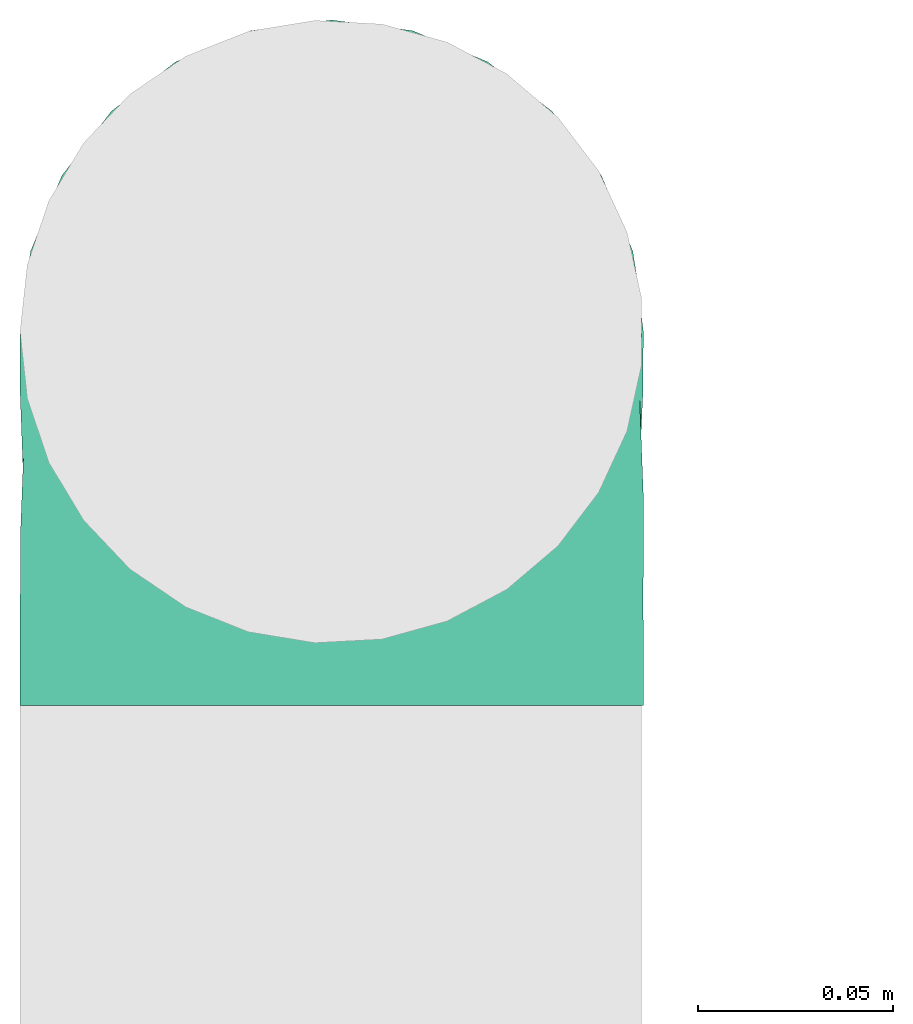
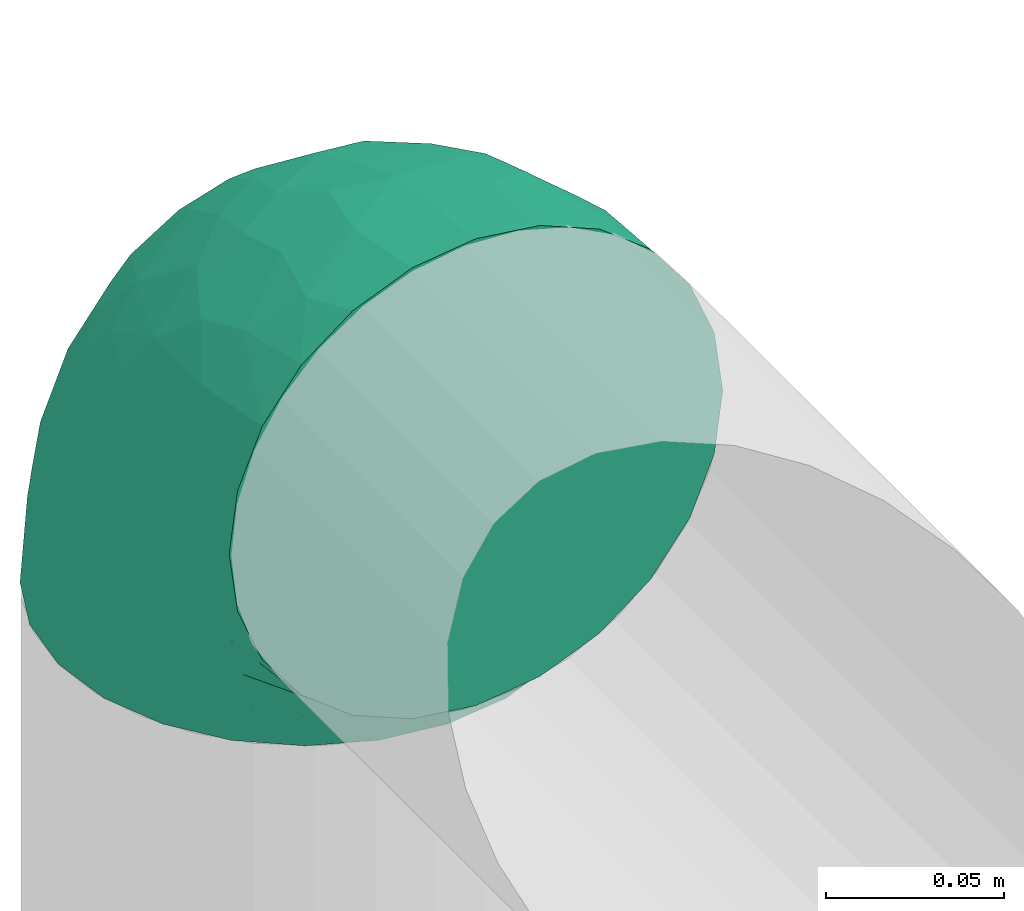
# One storey, part 10 of 12: 1 flow fitting.
"""IFC2X3 building model written with IfcOpenShell, lengths in millimetres."""

from ifc_helpers import new_model, entity, si_unit, converted_unit, derived_unit, direction, frame, origin, place, context, subcontext, project, spatial, faceted_brep, source, transform, mapped, type_object, type_shapes, element, save


model = new_model("IFC2X3")

# Units and contexts
model_context = context("Model", 3, precision=0.01, world=origin(), true_north=direction((6.12303176911189e-17, 1.0)))
body_context = subcontext(model_context, "Body", "Model", "MODEL_VIEW")
ifc_project = project(units=[si_unit("LENGTHUNIT", "METRE", prefix="MILLI"), si_unit("AREAUNIT", "SQUARE_METRE"), si_unit("VOLUMEUNIT", "CUBIC_METRE"), converted_unit("PLANEANGLEUNIT", "DEGREE", entity("IfcRatioMeasure", 0.0174532925199433), si_unit("PLANEANGLEUNIT", "RADIAN"), dimensions=[0, 0, 0, 0, 0, 0, 0]), si_unit("MASSUNIT", "GRAM", prefix="KILO"), derived_unit("MASSDENSITYUNIT", [(si_unit("MASSUNIT", "GRAM", prefix="KILO"), 1), (si_unit("LENGTHUNIT", "METRE"), -3)]), si_unit("TIMEUNIT", "SECOND"), si_unit("FREQUENCYUNIT", "HERTZ"), si_unit("THERMODYNAMICTEMPERATUREUNIT", "DEGREE_CELSIUS"), derived_unit("THERMALTRANSMITTANCEUNIT", [(si_unit("MASSUNIT", "GRAM", prefix="KILO"), 1), (si_unit("THERMODYNAMICTEMPERATUREUNIT", "KELVIN"), -1), (si_unit("TIMEUNIT", "SECOND"), -3)]), derived_unit("VOLUMETRICFLOWRATEUNIT", [(si_unit("LENGTHUNIT", "METRE"), 3), (si_unit("TIMEUNIT", "SECOND"), -1)]), si_unit("ELECTRICCURRENTUNIT", "AMPERE"), si_unit("ELECTRICVOLTAGEUNIT", "VOLT"), si_unit("POWERUNIT", "WATT"), si_unit("FORCEUNIT", "NEWTON", prefix="KILO"), si_unit("ILLUMINANCEUNIT", "LUX"), si_unit("LUMINOUSFLUXUNIT", "LUMEN"), si_unit("LUMINOUSINTENSITYUNIT", "CANDELA"), derived_unit("USERDEFINED", [(si_unit("MASSUNIT", "GRAM", prefix="KILO"), -1), (si_unit("LENGTHUNIT", "METRE"), -2), (si_unit("TIMEUNIT", "SECOND"), 3), (si_unit("LUMINOUSFLUXUNIT", "LUMEN"), 1)]), derived_unit("LINEARVELOCITYUNIT", [(si_unit("LENGTHUNIT", "METRE"), 1), (si_unit("TIMEUNIT", "SECOND"), -1)]), si_unit("PRESSUREUNIT", "PASCAL"), derived_unit("USERDEFINED", [(si_unit("LENGTHUNIT", "METRE"), -2), (si_unit("MASSUNIT", "GRAM", prefix="KILO"), 1), (si_unit("TIMEUNIT", "SECOND"), -2)])], contexts=[model_context])

# Site, building, storey
site_placement = place(None, origin())
site = spatial("IfcSite", under=ifc_project, at=site_placement, CompositionType="ELEMENT")
building_placement = place(site_placement, origin())
building = spatial("IfcBuilding", under=site, at=building_placement, CompositionType="ELEMENT")
storey_placement = place(building_placement, frame((0.0, 0.0, 8000.0)))
storey = spatial("IfcBuildingStorey", under=building, at=storey_placement, Name="02 Level", CompositionType="ELEMENT", Elevation=8000.0)

# Flow fitting
duct_fitting_type = type_object("IfcDuctFittingType", Name="Air_Elbow short_Circ", PredefinedType="NOTDEFINED")
shared_shape = source(origin(), body_context, "Body", "Brep", [
    faceted_brep([(-96.0, 0.0, -80.0), (-96.0, -20.7055236082018, -77.2740661031254), (-96.0, -40.0, -69.2820323027551), (-96.0, -56.5685424949239, -56.5685424949238), (-96.0, -69.2820323027551, -40.0), (-96.0, -77.2740661031255, -20.7055236082016), (-96.0, -80.0, 0.0), (-96.0, -77.2740661031253, 20.7055236082021), (-96.0, -69.2820323027549, 40.0), (-96.0, -56.5685424949235, 56.5685424949241), (-96.0, -40.0, 69.2820323027553), (-96.0, -30.3527618041005, 73.2780492029404), (-96.0, -20.7055236082013, 77.2740661031256), (-96.0, 0.0, 80.0), (-96.0, 20.705523608202, 77.2740661031254), (-96.0, 40.0, 69.2820323027549), (-96.0, 56.568542494924, 56.5685424949236), (-96.0, 69.2820323027553, 40.0), (-96.0, 77.2740661031256, 20.7055236082014), (-96.0, 80.0, 0.0), (-96.0, 77.2740661031254, -20.7055236082019), (-96.0, 69.282032302755, -40.0), (-96.0, 56.5685424949237, -56.5685424949239), (-96.0, 40.0, -69.2820323027552), (-96.0, 20.7055236082015, -77.2740661031255), (0.0, -96.0, -80.0), (20.7055236082025, -96.0, -77.2740661031255), (40.0, -96.0, -69.2820323027552), (56.5685424949246, -96.0, -56.5685424949239), (69.2820323027559, -96.0, -40.0), (77.2740661031264, -96.0, -20.7055236082019), (80.0, -96.0, 0.0), (77.2740661031265, -96.0, 20.7055236082014), (69.2820323027562, -96.0, 40.0), (56.5685424949249, -96.0, 56.5685424949236), (40.0, -96.0, 69.2820323027549), (20.7055236082029, -96.0, 77.2740661031254), (0.0, -96.0, 80.0), (-20.7055236082004, -96.0, 77.2740661031256), (-40.0, -96.0, 69.2820323027553), (-56.5685424949226, -96.0, 56.5685424949241), (-69.2820323027539, -96.0, 40.0), (-77.2740661031244, -96.0, 20.7055236082021), (-80.0, -96.0, 0.0), (-77.2740661031245, -96.0, -20.7055236082016), (-69.2820323027542, -96.0, -40.0), (-56.5685424949229, -96.0, -56.5685424949238), (-40.0, -96.0, -69.2820323027551), (-30.3527618041, -96.0, -73.2780492029402), (-20.7055236082008, -96.0, -77.2740661031254), (-69.6571465232348, -6.28172173912476, 79.9611058756859), (-66.7862289407348, 74.1387210661139, 22.9795507758541), (-78.4902527850466, 65.2482264041437, 44.9229732355936), (-55.1380888291464, 64.4450584799279, 39.5029426177976), (-75.1250134759213, -46.3506195730757, 68.0011973810265), (-79.9123689128389, -22.4151301859584, 77.2816866630488), (-67.1316735243184, 51.7530432423058, 58.5204707533666), (-62.9760666105318, 34.5362195419601, 70.0448030595901), (-46.2820694578435, 43.7397705581167, 60.5188244193914), (-76.2276812833835, 77.3969248578635, 0.0), (-50.4478480619551, 74.0029454268759, 0.0), (-6.30632028234235, -70.6421404093778, 79.9513108199466), (-27.189372084162, -68.980536479128, 76.8941402015288), (-29.8609237116382, 28.9682345099716, 65.8760199345924), (-47.7584488981354, 13.6212410427434, 76.3881123659885), (43.7397637815864, -46.2820598522933, 60.518827155348), (51.7530435574228, -67.1316742002235, 58.5204705859065), (57.6005967886466, -33.4719572927763, 39.0176496769077), (-74.2591571701267, 14.3645886695287, 78.2829835259588), (7.8513563843086, 42.4938374080907, 21.3232874317503), (23.3846344985257, 27.9066135199674, 24.7887114209846), (28.4507934888335, 28.4507934888321, 0.0), (-84.190871651952, -70.905997349447, 41.7100461919055), (10.21505333872, 32.0754161621096, 38.020212353501), (-0.0180155578363953, 25.9284255475521, 53.836744023285), (24.7272484782103, 2.06889411058577, 53.4325037134459), (-41.7574890626937, -15.123136403511, 79.988056483004), (-64.5619855594544, -27.52018553659, 77.2892967298799), (-8.0, 56.420471066061, 0.0), (-29.2239240309769, 65.2117082464685, 0.0), (-24.5336756868846, 60.9669573051438, 23.5003835585885), (-16.4008295437786, -51.3122057461681, 79.8609584412684), (-84.6862915010143, -84.6862915010152, 0.0), (-83.0529092063249, -83.0529092103045, 19.0855009657076), (-82.4185651555764, -62.2587017800419, 53.3339952483838), (-46.3022193149449, -75.902750025661, 67.8445262622594), (-9.5260688639158, 47.7232209131232, 35.4187162694583), (74.1387213421635, -66.7862279048973, 22.9795492840646), (34.536215572589, -62.976064096567, 70.0448048426748), (14.3645870599314, -74.259154996167, 78.2829837700474), (65.2482273833467, -78.4902510979302, 44.9229715327465), (-25.6317751341749, -1.2640655514879, 76.9124052095498), (-12.3935655196116, -25.4017250572252, 78.8652642576962), (60.9669574479924, -24.5336725945725, 23.5003789659965), (64.4450597015273, -55.1380839274934, 39.5029384026545), (69.8186739706361, -42.5625104806759, 16.7980672722629), (77.3969247188647, -76.2276802275763, 0.0), (74.002945426877, -50.4478480619565, 0.0), (-52.4774893100348, -53.0631556360015, 72.0041598972686), (-66.5995156060253, -66.5995146556305, 58.6370817132137), (-76.4857465466113, -78.9385356944492, 38.5867538667356), (-62.2587016209511, -82.4185645906685, 53.3339956492136), (13.6212369177471, -47.7584433090926, 76.3881128402526), (28.9682276847195, -29.8609133580269, 65.8760207540895), (-6.49930484510329, 53.7890406240985, 15.4645725223014), (-33.731289034344, -40.0214486160993, 79.0537019298314), (46.1336936566893, -26.2441492635858, 50.151541479116), (50.0005984633279, -1.26038287501495, 17.5763945268078), (56.4204710660622, -8.0, 0.0), (42.4356322774479, 10.225396744416, 0.0), (-45.4536887619888, 68.8356359385787, 23.6914879663761), (-33.3493864711472, 57.4572215948989, 39.1720709545353), (35.9683398342664, 11.0724559744972, 30.5391080332169), (-26.2441652621668, 46.1336984778153, 50.1515448602929), (36.6749123583047, 17.5982116941791, 14.5644188861001), (65.2117082464696, -29.2239240309784, 0.0), (49.5968730216335, -12.1440064858134, 34.8325942562253), (-47.1533280807863, -29.0746114834461, 78.9127210009486), (-0.981722938535007, -51.3162880079176, 79.4920802366619), (-1.95170750213435, -1.95169859379814, 70.9272590604952), (12.4951682569875, -20.0804783439543, 71.2292489374933), (13.0725391330592, -1.13338064801589, 63.5790506070627), (-1.93327092594732, 13.4823821925323, 63.7412032706882), (-18.9298205951927, 13.0048872663631, 70.6672094580024), (10.2253967444173, 42.4356322774466, 0.0), (-68.9805369123341, -27.1893702897943, -76.8941406355589), (-46.3506180288022, -75.1250185023919, -68.0011970559212), (-27.5201921618733, -64.5619784506715, -77.2892959136582), (-22.4151342180024, -79.9123577737124, -77.2816862456941), (-74.2591561090454, 14.364589592643, -78.2829832920378), (-66.78622820047, 74.1387209331735, -22.9795507950237), (-42.5625109127564, 69.8186736490614, -16.7980693145318), (-70.6421421271429, -6.30631801763141, -79.9513108797024), (-1.2640784754681, -25.6317655571971, -76.9124065444174), (-15.1231475192353, -41.7574898106582, -79.9880566497423), (-25.401718902627, -12.3935649209934, -78.8652635038296), (-82.4185656924104, -62.258701559575, -53.3339952529289), (-66.5995166501766, -66.5995137008527, -58.6370816545605), (-78.9385361639639, -76.4857467527193, -38.5867530236755), (53.7890400497189, -6.49930371043273, -15.4645720709197), (60.9669567069012, -24.5336743104721, -23.5003834743896), (-24.5336751436549, 60.9669572920351, -23.5003828649414), (-55.1380878256228, 64.4450583029017, -39.5029424837467), (-46.2820677406335, 43.7397707662098, -60.5188237522514), (-26.2441631797834, 46.1336980827234, -50.1515441608816), (-29.8609212227281, 28.9682353164184, -65.8760186412515), (74.1387206827049, -66.7862275406284, -22.9795512458422), (-40.0214489824224, -33.7312845774564, -79.0537024061946), (-78.4902524468744, 65.2482264004152, -44.9229731872606), (-75.902751427461, -46.3022186029078, -67.8445263463497), (-70.9059970555813, -84.1908706304995, -41.7100473389448), (-62.9760652707231, 34.536220162299, -70.044802546446), (-67.1316724627346, 51.7530434014037, -58.5204704180807), (-33.4719630839568, 57.6005950429912, -39.0176564793206), (-51.3122062597491, -16.4008248291117, -79.8609586691244), (-6.28171714934502, -69.65712797409, -79.9611061760713), (51.7530427306645, -67.1316703492073, -58.5204706539109), (-83.0529092397056, -83.0529091932979, -19.0855009185769), (68.8356349913375, -45.45368838847, -23.6914905340598), (-62.258701383479, -82.4185638376438, -53.3339962098694), (34.53621889603, -62.9760621802168, -70.0448028055675), (-1.26038544288408, 50.0005998980998, -17.5763953891677), (14.3645887716112, -74.2591526334116, -78.2829833202131), (13.6212385978137, -47.75844096294, -76.3881120677864), (65.2482261461557, -78.4902526871683, -44.9229735979605), (32.0754071702863, 10.2150656939878, -38.0202105656364), (25.9284207554091, -0.0180077987247146, -53.8367428868672), (2.068884460932, 24.7272580800759, -53.4325021883878), (47.723215348146, -9.52606271707191, -35.4187195087105), (42.4938359077841, 7.8513587520169, -21.3232866357369), (27.9066094773716, 23.3846413342612, -24.7887058003424), (28.9682309044935, -29.8609168472814, -65.8760199178674), (64.4450577206072, -55.1380878066959, -39.5029434692504), (-53.063150048133, -52.4774843719861, -72.0041634993662), (43.7397687897612, -46.2820667462245, -60.5188250739327), (-47.7584463040963, 13.6212426330217, -76.3881115880261), (57.4572201066452, -33.3493827160302, -39.1720708806551), (11.0724494499294, 35.9683446288498, -30.5391089716619), (46.1336964749623, -26.2441642243134, -50.1515465265606), (17.5982028158329, 36.6749194460897, -14.5644209948051), (-12.1440097531109, 49.5968729214507, -34.8325978072281), (-29.0746218055845, -47.1533256390974, -78.912719851915), (-51.3162911259858, -0.981717610547608, -79.4920798409907), (-1.95170139871169, -1.95169735730944, -70.9272563527003), (-20.0804667507281, 12.4951842966219, -71.2292388196267), (-1.13337124471279, 13.072540998247, -63.5790448193562), (13.4823844636247, -1.93327501577089, -63.7412039856557), (13.0048800657406, -18.9298191902065, -70.6672121474654)], [[[0, 1, 2, 3, 4, 5, 6, 7, 8, 9, 10, 11, 12, 13, 14, 15, 16, 17, 18, 19, 20, 21, 22, 23, 24]], [[25, 26, 27, 28, 29, 30, 31, 32, 33, 34, 35, 36, 37, 38, 39, 40, 41, 42, 43, 44, 45, 46, 47, 48, 49]], [[50, 13, 12]], [[51, 52, 53]], [[10, 54, 55]], [[56, 57, 58]], [[59, 51, 60]], [[61, 62, 38]], [[63, 57, 64]], [[65, 66, 67]], [[17, 16, 52]], [[15, 57, 56]], [[14, 13, 68]], [[69, 70, 71]], [[8, 7, 72]], [[68, 64, 57]], [[73, 74, 75]], [[76, 50, 77]], [[57, 15, 14]], [[9, 54, 10]], [[55, 12, 11, 10]], [[78, 79, 80]], [[62, 61, 81]], [[82, 83, 6]], [[63, 58, 57]], [[83, 7, 6]], [[8, 72, 84]], [[56, 16, 15]], [[84, 9, 8]], [[62, 85, 39]], [[86, 74, 73]], [[59, 18, 51]], [[18, 17, 51]], [[32, 87, 33]], [[35, 34, 66]], [[36, 88, 89]], [[90, 34, 33]], [[88, 36, 35]], [[91, 76, 92]], [[90, 33, 87]], [[93, 94, 95]], [[35, 66, 88]], [[32, 96, 87]], [[85, 40, 39]], [[87, 97, 95]], [[98, 99, 85]], [[41, 100, 42]], [[42, 100, 83]], [[101, 99, 100]], [[102, 88, 103]], [[43, 83, 82]], [[104, 78, 80]], [[38, 62, 39]], [[98, 85, 62]], [[92, 76, 105]], [[65, 106, 103]], [[101, 41, 40]], [[37, 61, 38]], [[107, 108, 109]], [[51, 53, 110]], [[37, 36, 89]], [[79, 110, 80]], [[110, 79, 60]], [[111, 110, 53]], [[112, 70, 73]], [[113, 86, 111]], [[71, 114, 109]], [[75, 103, 106]], [[93, 95, 115]], [[37, 89, 61]], [[108, 93, 115]], [[67, 93, 116]], [[107, 116, 93]], [[13, 50, 68]], [[117, 76, 77]], [[98, 117, 77]], [[99, 54, 84]], [[40, 85, 101]], [[98, 54, 99]], [[105, 62, 81]], [[89, 118, 61]], [[88, 66, 65]], [[94, 66, 90]], [[16, 56, 52]], [[111, 53, 56]], [[76, 64, 50]], [[64, 76, 91]], [[119, 92, 120]], [[61, 118, 81]], [[120, 121, 119]], [[116, 112, 75]], [[121, 122, 119]], [[119, 122, 123]], [[113, 63, 74]], [[119, 123, 91]], [[86, 113, 74]], [[122, 121, 75]], [[54, 98, 77]], [[105, 98, 62]], [[59, 19, 18]], [[97, 87, 96]], [[32, 31, 96]], [[102, 89, 88]], [[14, 68, 57]], [[64, 68, 50]], [[41, 101, 100]], [[99, 101, 85]], [[9, 84, 54]], [[100, 99, 72]], [[81, 92, 105]], [[102, 92, 118]], [[81, 118, 92]], [[102, 118, 89]], [[84, 72, 99]], [[83, 100, 72]], [[72, 7, 83]], [[42, 83, 43]], [[17, 52, 51]], [[53, 52, 56]], [[34, 90, 66]], [[94, 90, 87]], [[55, 54, 77]], [[55, 50, 12]], [[55, 77, 50]], [[60, 51, 110]], [[80, 110, 111]], [[86, 104, 80]], [[58, 113, 111]], [[111, 86, 80]], [[73, 69, 86]], [[69, 73, 70]], [[112, 73, 75]], [[69, 124, 104]], [[108, 107, 93]], [[112, 114, 70]], [[93, 67, 94]], [[112, 107, 114]], [[70, 114, 71]], [[109, 114, 107]], [[106, 116, 75]], [[116, 107, 112]], [[94, 67, 66]], [[67, 116, 106]], [[115, 95, 97]], [[69, 104, 86]], [[78, 104, 124]], [[69, 71, 124]], [[87, 95, 94]], [[88, 65, 103]], [[106, 65, 67]], [[56, 58, 111]], [[113, 58, 63]], [[117, 105, 76]], [[105, 117, 98]], [[63, 64, 123]], [[119, 91, 92]], [[91, 123, 64]], [[74, 63, 122]], [[123, 122, 63]], [[74, 122, 75]], [[121, 103, 75]], [[103, 121, 120]], [[120, 102, 103]], [[102, 120, 92]], [[1, 125, 2]], [[126, 127, 128]], [[129, 0, 24]], [[130, 60, 131]], [[0, 132, 1]], [[133, 134, 135]], [[136, 137, 138]], [[139, 108, 140]], [[3, 136, 4]], [[141, 142, 131]], [[138, 5, 4]], [[143, 144, 145]], [[30, 29, 146]], [[135, 134, 147]], [[148, 21, 130]], [[149, 3, 2]], [[20, 59, 130]], [[45, 44, 150]], [[151, 23, 152]], [[143, 152, 153]], [[152, 23, 22]], [[151, 24, 23]], [[125, 132, 154]], [[21, 148, 22]], [[155, 25, 49]], [[151, 129, 24]], [[20, 130, 21]], [[156, 28, 27]], [[157, 82, 6]], [[115, 158, 140]], [[157, 44, 43]], [[5, 138, 157]], [[150, 159, 45]], [[160, 27, 26]], [[161, 78, 124]], [[45, 159, 46]], [[128, 49, 48, 47]], [[2, 125, 149]], [[134, 155, 127]], [[162, 163, 160]], [[29, 28, 164]], [[126, 47, 46]], [[165, 166, 167]], [[25, 162, 26]], [[166, 165, 168]], [[132, 125, 1]], [[108, 115, 140]], [[169, 170, 71]], [[171, 160, 163]], [[27, 160, 156]], [[146, 164, 172]], [[173, 137, 149]], [[97, 96, 146]], [[171, 174, 160]], [[175, 151, 145]], [[160, 174, 156]], [[173, 149, 125]], [[47, 126, 128]], [[158, 115, 97]], [[6, 5, 157]], [[146, 172, 158]], [[96, 30, 146]], [[176, 158, 172]], [[177, 170, 165]], [[178, 168, 176]], [[71, 179, 124]], [[167, 145, 144]], [[141, 131, 79]], [[96, 31, 30]], [[78, 141, 79]], [[153, 141, 180]], [[161, 180, 141]], [[25, 155, 162]], [[147, 134, 181]], [[173, 181, 127]], [[137, 126, 159]], [[3, 149, 136]], [[173, 126, 137]], [[147, 125, 154]], [[129, 182, 132]], [[151, 152, 143]], [[142, 152, 148]], [[28, 156, 164]], [[176, 172, 156]], [[134, 163, 155]], [[163, 134, 133]], [[183, 135, 184]], [[132, 182, 154]], [[184, 185, 183]], [[180, 177, 167]], [[185, 186, 183]], [[183, 186, 187]], [[178, 171, 166]], [[183, 187, 133]], [[168, 178, 166]], [[186, 185, 167]], [[126, 173, 127]], [[147, 173, 125]], [[60, 130, 59]], [[20, 19, 59]], [[0, 129, 132]], [[175, 129, 151]], [[26, 162, 160]], [[163, 162, 155]], [[4, 136, 138]], [[137, 136, 149]], [[46, 159, 126]], [[138, 137, 150]], [[154, 135, 147]], [[175, 135, 182]], [[154, 182, 135]], [[175, 182, 129]], [[159, 150, 137]], [[157, 138, 150]], [[82, 157, 43]], [[150, 44, 157]], [[29, 164, 146]], [[172, 164, 156]], [[22, 148, 152]], [[142, 148, 130]], [[155, 128, 127]], [[128, 155, 49]], [[97, 146, 158]], [[140, 158, 176]], [[168, 139, 140]], [[174, 178, 176]], [[176, 168, 140]], [[165, 169, 168]], [[169, 165, 170]], [[177, 165, 167]], [[169, 109, 139]], [[78, 161, 141]], [[177, 179, 170]], [[141, 153, 142]], [[177, 161, 179]], [[170, 179, 71]], [[124, 179, 161]], [[144, 180, 167]], [[180, 161, 177]], [[142, 153, 152]], [[153, 180, 144]], [[79, 131, 60]], [[169, 139, 168]], [[108, 139, 109]], [[169, 71, 109]], [[130, 131, 142]], [[151, 143, 145]], [[144, 143, 153]], [[156, 174, 176]], [[178, 174, 171]], [[147, 181, 173]], [[181, 134, 127]], [[171, 163, 187]], [[183, 133, 135]], [[133, 187, 163]], [[166, 171, 186]], [[187, 186, 171]], [[166, 186, 167]], [[185, 145, 167]], [[145, 185, 184]], [[184, 175, 145]], [[175, 184, 135]]]),
])
type_shapes(duct_fitting_type, [shared_shape])
flow_fitting_placement = place(storey_placement, frame((22191.748982204, -67076.2395851399, 3000.0), z_axis=(-1.0, 0.0, 0.0), x_axis=(0.0, 0.0, 1.0)))
element("IfcFlowFitting", 1, at=flow_fitting_placement, inside=storey, type_object=duct_fitting_type, Name="elbow_short_001:Air_Elbow short_Circ", ObjectType="elbow_short_001:Air_Elbow short_Circ", context=body_context, shape_type="MappedRepresentation", body=[
    mapped(shared_shape, transform((0.0, 0.0, 0.0), scale=1.0)),
])

save(model, "model.ifc")
